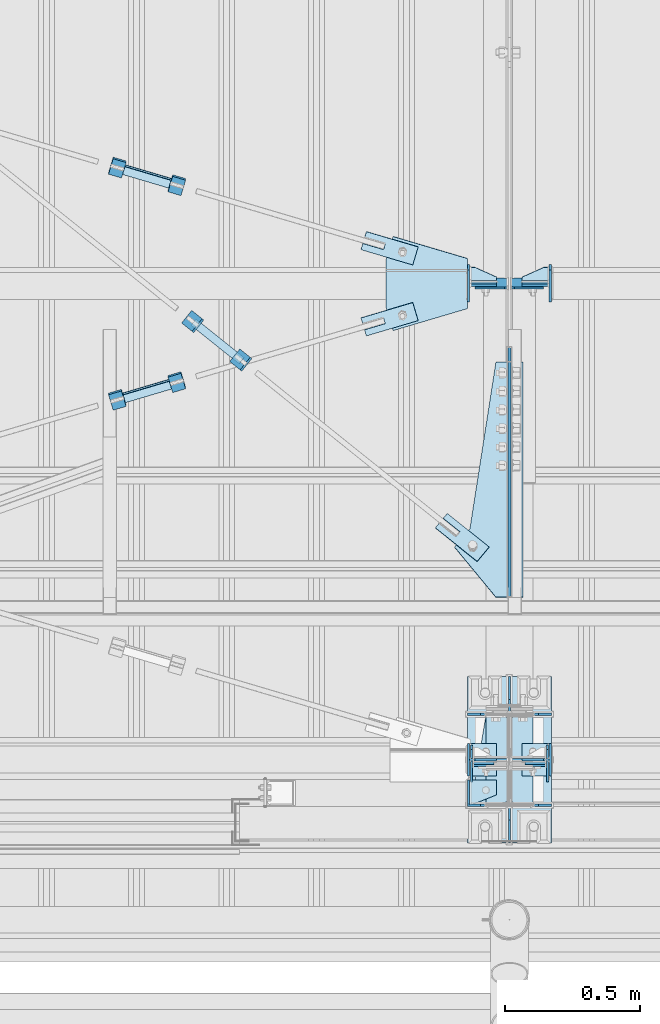
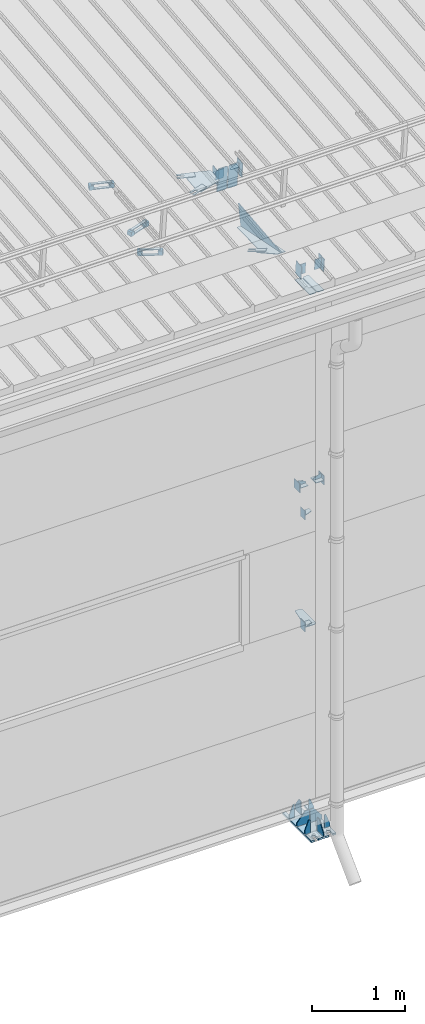
# One storey, part 112 of 709: 52 plates, 6 openings, 16 elements without a shape of their own.
"""IFC4 building model written with IfcOpenShell, lengths in millimetres."""

from ifc_helpers import new_model, si_unit, direction, frame, origin_with_axes, place, context, subcontext, project, spatial, line, arc, indexed_curve, outline, extrude, material, element, aggregate, save


model = new_model("IFC4")

# Units and contexts
model_context = context("Model", 3, precision=0.2, world=origin_with_axes(), true_north=direction((0.0, 1.0)))
body_context = subcontext(model_context, "Body", "Model", "MODEL_VIEW")
ifc_project = project(units=[si_unit("LENGTHUNIT", "METRE", prefix="MILLI"), si_unit("AREAUNIT", "SQUARE_METRE"), si_unit("VOLUMEUNIT", "CUBIC_METRE"), si_unit("MASSUNIT", "GRAM", prefix="KILO"), si_unit("TIMEUNIT", "SECOND"), si_unit("PLANEANGLEUNIT", "RADIAN"), si_unit("SOLIDANGLEUNIT", "STERADIAN"), si_unit("THERMODYNAMICTEMPERATUREUNIT", "DEGREE_CELSIUS"), si_unit("LUMINOUSINTENSITYUNIT", "LUMEN")], contexts=[model_context])

# Site, building, storey
site_placement = place(None, origin_with_axes())
site = spatial("IfcSite", under=ifc_project, at=site_placement, CompositionType="ELEMENT")
building_placement = place(site_placement, origin_with_axes())
building = spatial("IfcBuilding", under=site, at=building_placement, Name="Undefined", CompositionType="ELEMENT")
storey_placement = place(building_placement, origin_with_axes())
storey = spatial("IfcBuildingStorey", under=building, at=storey_placement, Name="Undefined", CompositionType="ELEMENT", Elevation=0.0)

# Assembly, plates, voiding features
assembly_1_placement = place(storey_placement, frame((10000.0, 173.0, -200.0), z_axis=(-1.0, 0.0, 0.0), x_axis=(0.0, 0.0, 1.0)))
assembly_1 = element("IfcElementAssembly", 1, at=assembly_1_placement, inside=storey)
ifc_material_1 = material(Name="C355-6", Category="STEEL")
plate_1_placement = place(assembly_1_placement, frame((2742.0, 163.0, 4.0), z_axis=(1.0, 0.0, 0.0), x_axis=(0.0, 0.0, 1.0)))
plate_1 = element("IfcPlate", 2, at=plate_1_placement, material=ifc_material_1, ObjectType="543", context=body_context, shape_type="SolidModel", body=[
    extrude(outline(indexed_curve([(0.0, 20.0), (20.0, 0.0), (83.0, 0.0), (123.0, 240.0), (123.0, 326.0), (20.0, 326.0), (0.0, 306.0)], segments=[line(1, 2, 3, 4, 5, 6, 7, 1)])), frame((0.0, 0.0, 4.0), z_axis=(0.0, 0.0, 1.0), x_axis=(1.0, 0.0, 0.0)), (0.0, 0.0, -1.0), 8.0),
])
plate_2_placement = place(assembly_1_placement, frame((7097.93718, 163.0, 87.0), z_axis=(-1.0, 0.0, 0.0), x_axis=(0.0, 0.0, -1.0)))
plate_2 = element("IfcPlate", 3, at=plate_2_placement, material=ifc_material_1, ObjectType="461", context=body_context, shape_type="SolidModel", body=[
    extrude(outline(indexed_curve([(0.0, 0.0), (68.0, 0.0), (83.0, 15.0), (83.0, 311.0), (68.0, 326.0), (0.0, 326.0)], segments=[line(1, 2, 3, 4, 5, 6, 1)])), frame((0.0, 0.0, 4.0), z_axis=(0.0, 0.0, 1.0), x_axis=(1.0, 0.0, 0.0)), (0.0, 0.0, -1.0), 8.0),
])
plate_3_placement = place(assembly_1_placement, frame((7097.93718, -163.0, -87.0), z_axis=(-1.0, 0.0, 0.0), x_axis=(0.0, 0.0, 1.0)))
plate_3 = element("IfcPlate", 4, at=plate_3_placement, material=ifc_material_1, ObjectType="461", context=body_context, shape_type="SolidModel", body=[
    extrude(outline(indexed_curve([(0.0, 0.0), (68.0, 0.0), (83.0, 15.0), (83.0, 311.0), (68.0, 326.0), (0.0, 326.0)], segments=[line(1, 2, 3, 4, 5, 6, 1)])), frame((0.0, 0.0, 4.0), z_axis=(0.0, 0.0, 1.0), x_axis=(1.0, 0.0, 0.0)), (0.0, 0.0, -1.0), 8.0),
])
plate_4_placement = place(assembly_1_placement, frame((25.0, -173.0, 0.0), z_axis=(0.0, 0.0, 1.0), x_axis=(0.0, -1.0, 0.0)))
plate_4 = element("IfcPlate", 5, at=plate_4_placement, material=ifc_material_1, ObjectType="418", context=body_context, shape_type="SolidModel", body=[
    extrude(outline(indexed_curve([(0.0, 0.0), (135.0, 0.0), (135.0, 50.0), (50.0, 175.0), (0.0, 175.0)], segments=[line(1, 2, 3, 4, 5, 1)])), frame((0.0, 0.0, 4.0), z_axis=(0.0, 0.0, 1.0), x_axis=(1.0, 0.0, 0.0)), (0.0, 0.0, -1.0), 8.0),
])
plate_5_placement = place(assembly_1_placement, frame((25.0, 173.0, 0.0), z_axis=(0.0, 0.0, -1.0), x_axis=(0.0, 1.0, 0.0)))
plate_5 = element("IfcPlate", 6, at=plate_5_placement, material=ifc_material_1, ObjectType="418", context=body_context, shape_type="SolidModel", body=[
    extrude(outline(indexed_curve([(0.0, 0.0), (135.0, 0.0), (135.0, 50.0), (50.0, 175.0), (0.0, 175.0)], segments=[line(1, 2, 3, 4, 5, 1)])), frame((0.0, 0.0, 4.0), z_axis=(0.0, 0.0, 1.0), x_axis=(1.0, 0.0, 0.0)), (0.0, 0.0, -1.0), 8.0),
])
plate_6_placement = place(assembly_1_placement, frame((25.0, 168.5, -87.0), z_axis=(0.0, -1.0, 0.0), x_axis=(0.0, 0.0, -1.0)))
plate_6 = element("IfcPlate", 7, at=plate_6_placement, material=ifc_material_1, ObjectType="419", context=body_context, shape_type="SolidModel", body=[
    extrude(outline(indexed_curve([(0.0, 0.0), (68.0, 0.0), (68.0, 50.0), (20.0, 175.0), (0.0, 175.0)], segments=[line(1, 2, 3, 4, 5, 1)])), frame((0.0, 0.0, 4.0), z_axis=(0.0, 0.0, 1.0), x_axis=(1.0, 0.0, 0.0)), (0.0, 0.0, -1.0), 8.0),
])
plate_7_placement = place(assembly_1_placement, frame((25.0, -168.5, 87.0), z_axis=(0.0, 1.0, 0.0), x_axis=(0.0, 0.0, 1.0)))
plate_7 = element("IfcPlate", 8, at=plate_7_placement, material=ifc_material_1, ObjectType="419", context=body_context, shape_type="SolidModel", body=[
    extrude(outline(indexed_curve([(0.0, 0.0), (68.0, 0.0), (68.0, 50.0), (20.0, 175.0), (0.0, 175.0)], segments=[line(1, 2, 3, 4, 5, 1)])), frame((0.0, 0.0, 4.0), z_axis=(0.0, 0.0, 1.0), x_axis=(1.0, 0.0, 0.0)), (0.0, 0.0, -1.0), 8.0),
])
plate_8_placement = place(assembly_1_placement, frame((25.0, -168.5, -87.0), z_axis=(0.0, -1.0, 0.0), x_axis=(0.0, 0.0, -1.0)))
plate_8 = element("IfcPlate", 9, at=plate_8_placement, material=ifc_material_1, ObjectType="419", context=body_context, shape_type="SolidModel", body=[
    extrude(outline(indexed_curve([(0.0, 0.0), (68.0, 0.0), (68.0, 50.0), (20.0, 175.0), (0.0, 175.0)], segments=[line(1, 2, 3, 4, 5, 1)])), frame((0.0, 0.0, 4.0), z_axis=(0.0, 0.0, 1.0), x_axis=(1.0, 0.0, 0.0)), (0.0, 0.0, -1.0), 8.0),
])
plate_9_placement = place(assembly_1_placement, frame((25.0, 168.5, 87.0), z_axis=(0.0, 1.0, 0.0), x_axis=(0.0, 0.0, 1.0)))
plate_9 = element("IfcPlate", 10, at=plate_9_placement, material=ifc_material_1, ObjectType="419", context=body_context, shape_type="SolidModel", body=[
    extrude(outline(indexed_curve([(0.0, 0.0), (68.0, 0.0), (68.0, 50.0), (20.0, 175.0), (0.0, 175.0)], segments=[line(1, 2, 3, 4, 5, 1)])), frame((0.0, 0.0, 4.0), z_axis=(0.0, 0.0, 1.0), x_axis=(1.0, 0.0, 0.0)), (0.0, 0.0, -1.0), 8.0),
])
plate_10_placement = place(assembly_1_placement, frame((25.0, 0.0, -3.0), z_axis=(0.0, -1.0, 0.0), x_axis=(0.0, 0.0, -1.0)))
plate_10 = element("IfcPlate", 11, at=plate_10_placement, material=ifc_material_1, ObjectType="417", context=body_context, shape_type="SolidModel", body=[
    extrude(outline(indexed_curve([(0.0, 0.0), (152.0, 0.0), (152.0, 50.0), (50.0, 175.0), (0.0, 175.0)], segments=[line(1, 2, 3, 4, 5, 1)])), frame((0.0, 0.0, 4.0), z_axis=(0.0, 0.0, 1.0), x_axis=(1.0, 0.0, 0.0)), (0.0, 0.0, -1.0), 8.0),
])
plate_11_placement = place(assembly_1_placement, frame((12.5, -308.0, 155.0), z_axis=(1.0, 0.0, 0.0), x_axis=(0.0, 0.0, -1.0)))
plate_11 = element("IfcPlate", 12, at=plate_11_placement, material=ifc_material_1, ObjectType="416", context=body_context, shape_type="SolidModel", body=[
    extrude(outline(indexed_curve([(0.0, 0.0), (310.0, 0.0), (310.0, 616.0), (0.0, 616.0)], segments=[line(1, 2, 3, 4, 1)])), frame((0.0, 0.0, 12.5), z_axis=(0.0, 0.0, 1.0), x_axis=(1.0, 0.0, 0.0)), (0.0, 0.0, -1.0), 25.0),
])
voiding_feature_1_placement = place(plate_11_placement, frame((40.0, 616.0, 0.0), z_axis=(0.0, 0.0, -1.0), x_axis=(1.0, 0.0, 0.0)))
element("IfcVoidingFeature", 13, at=voiding_feature_1_placement, cuts=plate_11, PredefinedType="HOLE", context=body_context, shape_type="SolidModel", body=[
    extrude(outline(indexed_curve([(0.0, 0.0), (50.0, 0.0), (50.0, 60.0), (42.67767, 77.67767), (25.0, 85.0), (25.0, 85.0), (7.32233, 77.67767), (0.0, 60.0)], segments=[line(1, 2, 3), arc(3, 4, 5), line(5, 6), arc(6, 7, 8), line(8, 1)])), frame((0.0, 0.0, 12.5), z_axis=(0.0, 0.0, 1.0), x_axis=(1.0, 0.0, 0.0)), (0.0, 0.0, -1.0), 25.0),
])
voiding_feature_2_placement = place(plate_11_placement, frame((40.0, 0.0, 0.0), z_axis=(0.0, 0.0, 1.0), x_axis=(1.0, 0.0, 0.0)))
element("IfcVoidingFeature", 14, at=voiding_feature_2_placement, cuts=plate_11, PredefinedType="HOLE", context=body_context, shape_type="SolidModel", body=[
    extrude(outline(indexed_curve([(0.0, 0.0), (50.0, 0.0), (50.0, 60.0), (42.67767, 77.67767), (25.0, 85.0), (25.0, 85.0), (7.32233, 77.67767), (0.0, 60.0)], segments=[line(1, 2, 3), arc(3, 4, 5), line(5, 6), arc(6, 7, 8), line(8, 1)])), frame((0.0, 0.0, 12.5), z_axis=(0.0, 0.0, 1.0), x_axis=(1.0, 0.0, 0.0)), (0.0, 0.0, -1.0), 25.0),
])
voiding_feature_3_placement = place(plate_11_placement, frame((270.0, 616.0, 0.0), z_axis=(0.0, 0.0, 1.0), x_axis=(-1.0, 0.0, 0.0)))
element("IfcVoidingFeature", 15, at=voiding_feature_3_placement, cuts=plate_11, PredefinedType="HOLE", context=body_context, shape_type="SolidModel", body=[
    extrude(outline(indexed_curve([(0.0, 0.0), (50.0, 0.0), (50.0, 60.0), (42.67767, 77.67767), (25.0, 85.0), (25.0, 85.0), (7.32233, 77.67767), (0.0, 60.0)], segments=[line(1, 2, 3), arc(3, 4, 5), line(5, 6), arc(6, 7, 8), line(8, 1)])), frame((0.0, 0.0, 12.5), z_axis=(0.0, 0.0, 1.0), x_axis=(1.0, 0.0, 0.0)), (0.0, 0.0, -1.0), 25.0),
])
voiding_feature_4_placement = place(plate_11_placement, frame((270.0, 0.0, 0.0), z_axis=(0.0, 0.0, -1.0), x_axis=(-1.0, 0.0, 0.0)))
element("IfcVoidingFeature", 16, at=voiding_feature_4_placement, cuts=plate_11, PredefinedType="HOLE", context=body_context, shape_type="SolidModel", body=[
    extrude(outline(indexed_curve([(0.0, 0.0), (50.0, 0.0), (50.0, 60.0), (42.67767, 77.67767), (25.0, 85.0), (25.0, 85.0), (7.32233, 77.67767), (0.0, 60.0)], segments=[line(1, 2, 3), arc(3, 4, 5), line(5, 6), arc(6, 7, 8), line(8, 1)])), frame((0.0, 0.0, 12.5), z_axis=(0.0, 0.0, 1.0), x_axis=(1.0, 0.0, 0.0)), (0.0, 0.0, -1.0), 25.0),
])
plate_12_placement = place(assembly_1_placement, frame((25.0, 0.0, 3.0), z_axis=(0.0, 1.0, 0.0), x_axis=(0.0, 0.0, 1.0)))
plate_12 = element("IfcPlate", 17, at=plate_12_placement, material=ifc_material_1, ObjectType="417", context=body_context, shape_type="SolidModel", body=[
    extrude(outline(indexed_curve([(0.0, 0.0), (152.0, 0.0), (152.0, 50.0), (50.0, 175.0), (0.0, 175.0)], segments=[line(1, 2, 3, 4, 5, 1)])), frame((0.0, 0.0, 4.0), z_axis=(0.0, 0.0, 1.0), x_axis=(1.0, 0.0, 0.0)), (0.0, 0.0, -1.0), 8.0),
])
aggregate(assembly_1, [plate_1, plate_2, plate_3, plate_4, plate_5, plate_6, plate_7, plate_8, plate_9, plate_10, plate_11, plate_12])

# Assembly, plates
assembly_2_placement = place(storey_placement, frame((10000.0, 346.0, 7089.70002), z_axis=(1.0, 0.0, 0.0), x_axis=(0.0, 0.9950371902, 0.099503719)))
assembly_2 = element("IfcElementAssembly", 18, at=assembly_2_placement, inside=storey)
plate_13_placement = place(assembly_2_placement, frame((412.62035, -176.8248, 50.0), z_axis=(0.2927142719, 0.9561999556, 0.0), x_axis=(0.9561999556, -0.2927142719, 0.0)))
plate_13 = element("IfcPlate", 19, at=plate_13_placement, material=ifc_material_1, ObjectType="489", context=body_context, shape_type="SolidModel", body=[
    extrude(outline(indexed_curve([(0.0, 0.0), (887.65935, 0.0), (887.65935, 100.0), (259.05365, 196.23068), (189.37305, 253.1922), (0.0, 100.0)], segments=[line(1, 2, 3, 4, 5, 6, 1)])), frame((0.0, 0.0, 4.0), z_axis=(0.0, 0.0, 1.0), x_axis=(1.0, 0.0, 0.0)), (0.0, 0.0, -1.0), 8.0),
])
plate_14_placement = place(assembly_2_placement, frame((1342.111, -173.0, 0.0), z_axis=(0.0, 0.0, 1.0), x_axis=(-1.0, 0.0, 0.0)))
plate_14 = element("IfcPlate", 20, at=plate_14_placement, material=ifc_material_1, ObjectType="449", context=body_context, shape_type="SolidModel", body=[
    extrude(outline(indexed_curve([(0.0, 0.0), (928.3198, 0.0), (79.53997, 259.83056)], segments=[line(1, 2, 3, 1)])), frame((0.0, 0.0, 6.0), z_axis=(0.0, 0.0, 1.0), x_axis=(1.0, 0.0, 0.0)), (0.0, 0.0, -1.0), 12.0),
])
plate_15_placement = place(assembly_2_placement, frame((1597.88359, 163.0, -127.0), z_axis=(1.0, 0.0, 0.0), x_axis=(0.0, 0.0, 1.0)))
plate_15 = element("IfcPlate", 21, at=plate_15_placement, material=ifc_material_1, ObjectType="585", context=body_context, shape_type="SolidModel", body=[
    extrude(outline(indexed_curve([(0.0, 0.0), (108.0, 0.0), (123.0, 15.0), (123.0, 311.0), (108.0, 326.0), (0.0, 326.0)], segments=[line(1, 2, 3, 4, 5, 6, 1)])), frame((0.0, 0.0, 4.0), z_axis=(0.0, 0.0, 1.0), x_axis=(1.0, 0.0, 0.0)), (0.0, 0.0, -1.0), 8.0),
])
plate_16_placement = place(assembly_2_placement, frame((1597.88359, 163.0, 127.0), z_axis=(-1.0, 0.0, 0.0), x_axis=(0.0, 0.0, -1.0)))
plate_16 = element("IfcPlate", 22, at=plate_16_placement, material=ifc_material_1, ObjectType="585", context=body_context, shape_type="SolidModel", body=[
    extrude(outline(indexed_curve([(0.0, 0.0), (108.0, 0.0), (123.0, 15.0), (123.0, 311.0), (108.0, 326.0), (0.0, 326.0)], segments=[line(1, 2, 3, 4, 5, 6, 1)])), frame((0.0, 0.0, 4.0), z_axis=(0.0, 0.0, 1.0), x_axis=(1.0, 0.0, 0.0)), (0.0, 0.0, -1.0), 8.0),
])
aggregate(assembly_2, [plate_13, plate_14, plate_15, plate_16])

# Assembly, plate
assembly_3_placement = place(storey_placement, frame((8916.07962, 1724.40956, 6772.92001), z_axis=(-0.625451877, -0.7802627439, 1e-10), x_axis=(0.7742288439, -0.6206151549, 0.124123031)))
assembly_3 = element("IfcElementAssembly", 23, at=assembly_3_placement, inside=storey)
plate_17_placement = place(assembly_3_placement, frame((1074.34134, 5.35577, 34.5878), z_axis=(1e-10, 0.9882227648, -0.1530221135), x_axis=(1.0, 0.0, 0.0)))
plate_17 = element("IfcPlate", 24, at=plate_17_placement, material=ifc_material_1, ObjectType="490", context=body_context, shape_type="SolidModel", body=[
    extrude(outline(indexed_curve([(0.0, 0.0), (200.0, 0.0), (200.0, 70.0), (0.0, 70.0), (0.0, 46.0), (80.0, 46.0), (80.0, 24.0), (0.0, 24.0)], segments=[line(1, 2, 3, 4, 5, 6, 7, 8, 1)])), frame((0.0, 0.0, 4.0), z_axis=(0.0, 0.0, 1.0), x_axis=(1.0, 0.0, 0.0)), (0.0, 0.0, -1.0), 8.0),
])
aggregate(assembly_3, [plate_17])

# Assembly, plates
assembly_4_placement = place(storey_placement, frame((8983.44692, 1631.95992, 6816.96217), z_axis=(-0.7742288439, 0.6206151548, -0.1241230313), x_axis=(0.625451877, 0.780262744, 0.0)))
assembly_4 = element("IfcElementAssembly", 25, at=assembly_4_placement, inside=storey)
ifc_material_2 = material(Name="Steel_Undefined", Category="STEEL")
plate_18_placement = place(assembly_4_placement, origin_with_axes())
plate_18 = element("IfcPlate", 26, at=plate_18_placement, material=ifc_material_2, ObjectType="482", context=body_context, shape_type="SolidModel", body=[
    extrude(outline(indexed_curve([(0.0, 0.0), (60.0, 0.0), (60.0, 60.0), (0.0, 60.0)], segments=[line(1, 2, 3, 4, 1)])), frame((0.0, 0.0, 25.0), z_axis=(0.0, 0.0, 1.0), x_axis=(1.0, 0.0, 0.0)), (0.0, 0.0, -1.0), 50.0),
])
plate_19_placement = place(assembly_4_placement, frame((15.0, 66.0, 230.0), z_axis=(0.0, 1.0, 0.0), x_axis=(1.0, 0.0, 0.0)))
plate_19 = element("IfcPlate", 27, at=plate_19_placement, material=ifc_material_2, ObjectType="484", context=body_context, shape_type="SolidModel", body=[
    extrude(outline(indexed_curve([(0.0, 0.0), (30.0, 0.0), (30.0, 230.0), (0.0, 230.0)], segments=[line(1, 2, 3, 4, 1)])), frame((0.0, 0.0, 6.0), z_axis=(0.0, 0.0, 1.0), x_axis=(1.0, 0.0, 0.0)), (0.0, 0.0, -1.0), 12.0),
])
plate_20_placement = place(assembly_4_placement, frame((15.0, -6.0, 230.0), z_axis=(0.0, 1.0, 0.0), x_axis=(1.0, 0.0, 0.0)))
plate_20 = element("IfcPlate", 28, at=plate_20_placement, material=ifc_material_2, ObjectType="484", context=body_context, shape_type="SolidModel", body=[
    extrude(outline(indexed_curve([(0.0, 0.0), (30.0, 0.0), (30.0, 230.0), (0.0, 230.0)], segments=[line(1, 2, 3, 4, 1)])), frame((0.0, 0.0, 6.0), z_axis=(0.0, 0.0, 1.0), x_axis=(1.0, 0.0, 0.0)), (0.0, 0.0, -1.0), 12.0),
])
plate_21_placement = place(assembly_4_placement, frame((0.0, 0.0, 230.0), z_axis=(0.0, 0.0, 1.0), x_axis=(1.0, 0.0, 0.0)))
plate_21 = element("IfcPlate", 29, at=plate_21_placement, material=ifc_material_2, ObjectType="483", context=body_context, shape_type="SolidModel", body=[
    extrude(outline(indexed_curve([(0.0, 0.0), (60.0, 0.0), (60.0, 60.0), (0.0, 60.0)], segments=[line(1, 2, 3, 4, 1)])), frame((0.0, 0.0, 25.0), z_axis=(0.0, 0.0, 1.0), x_axis=(1.0, 0.0, 0.0)), (0.0, 0.0, -1.0), 50.0),
])
aggregate(assembly_4, [plate_18, plate_19, plate_20, plate_21])

assembly_5_placement = place(storey_placement, frame((4000.0, 50.0, 2550.0), z_axis=(0.0, 0.0, -1.0), x_axis=(1.0, 0.0, 0.0)))
assembly_5 = element("IfcElementAssembly", 30, at=assembly_5_placement, inside=storey)
plate_22_placement = place(assembly_5_placement, frame((5849.0, 47.0, -60.0), z_axis=(-1.0, 0.0, 0.0), x_axis=(0.0, -1.0, 0.0)))
plate_22 = element("IfcPlate", 31, at=plate_22_placement, material=ifc_material_1, ObjectType="501", context=body_context, shape_type="SolidModel", body=[
    extrude(outline(indexed_curve([(0.0, 0.0), (94.0, 0.0), (94.0, 120.0), (0.0, 120.0)], segments=[line(1, 2, 3, 4, 1)])), frame((0.0, 0.0, 4.0), z_axis=(0.0, 0.0, 1.0), x_axis=(1.0, 0.0, 0.0)), (0.0, 0.0, -1.0), 8.0),
])
plate_23_placement = place(assembly_5_placement, frame((5853.0, 47.0, 0.0), z_axis=(0.0, 0.0, 1.0), x_axis=(0.0, -1.0, 0.0)))
plate_23 = element("IfcPlate", 32, at=plate_23_placement, material=ifc_material_1, ObjectType="502", context=body_context, shape_type="SolidModel", body=[
    extrude(outline(indexed_curve([(0.0, 0.0), (94.0, 0.0), (94.0, 100.0), (40.0, 100.0), (0.0, 0.0)], segments=[line(1, 2, 3, 4, 5, 1)])), frame((0.0, 0.0, 4.0), z_axis=(0.0, 0.0, 1.0), x_axis=(1.0, 0.0, 0.0)), (0.0, 0.0, -1.0), 8.0),
])
aggregate(assembly_5, [plate_22, plate_23])

assembly_6_placement = place(storey_placement, frame((4000.0, 50.0, 4020.0), z_axis=(0.0, 0.0, -1.0), x_axis=(1.0, 0.0, 0.0)))
assembly_6 = element("IfcElementAssembly", 33, at=assembly_6_placement, inside=storey)
plate_24_placement = place(assembly_6_placement, frame((5853.0, 47.0, 0.0), z_axis=(0.0, 0.0, 1.0), x_axis=(0.0, -1.0, 0.0)))
plate_24 = element("IfcPlate", 34, at=plate_24_placement, material=ifc_material_1, ObjectType="502", context=body_context, shape_type="SolidModel", body=[
    extrude(outline(indexed_curve([(0.0, 0.0), (94.0, 0.0), (94.0, 100.0), (40.0, 100.0), (0.0, 0.0)], segments=[line(1, 2, 3, 4, 5, 1)])), frame((0.0, 0.0, 4.0), z_axis=(0.0, 0.0, 1.0), x_axis=(1.0, 0.0, 0.0)), (0.0, 0.0, -1.0), 8.0),
])
plate_25_placement = place(assembly_6_placement, frame((5849.0, 47.0, -60.0), z_axis=(-1.0, 0.0, 0.0), x_axis=(0.0, -1.0, 0.0)))
plate_25 = element("IfcPlate", 35, at=plate_25_placement, material=ifc_material_1, ObjectType="501", context=body_context, shape_type="SolidModel", body=[
    extrude(outline(indexed_curve([(0.0, 0.0), (94.0, 0.0), (94.0, 120.0), (0.0, 120.0)], segments=[line(1, 2, 3, 4, 1)])), frame((0.0, 0.0, 4.0), z_axis=(0.0, 0.0, 1.0), x_axis=(1.0, 0.0, 0.0)), (0.0, 0.0, -1.0), 8.0),
])
aggregate(assembly_6, [plate_24, plate_25])

assembly_7_placement = place(storey_placement, frame((4000.0, 173.0, 4310.0), z_axis=(0.0, 0.0, -1.0), x_axis=(1.0, 0.0, 0.0)))
assembly_7 = element("IfcElementAssembly", 36, at=assembly_7_placement, inside=storey)
plate_26_placement = place(assembly_7_placement, frame((5953.0, 0.0, -60.0), z_axis=(0.0, -1.0, 0.0), x_axis=(0.0, 0.0, 1.0)))
plate_26 = element("IfcPlate", 37, at=plate_26_placement, material=ifc_material_1, ObjectType="508", context=body_context, shape_type="SolidModel", body=[
    extrude(outline(indexed_curve([(0.0, 80.0), (36.0, 0.0), (56.0, 0.0), (56.0, 90.0), (46.0, 100.0), (0.0, 100.0)], segments=[line(1, 2, 3, 4, 5, 6, 1)])), frame((0.0, 0.0, 4.0), z_axis=(0.0, 0.0, 1.0), x_axis=(1.0, 0.0, 0.0)), (0.0, 0.0, -1.0), 8.0),
])
plate_27_placement = place(assembly_7_placement, frame((5849.0, -60.0, 60.0), z_axis=(1.0, 0.0, 0.0), x_axis=(0.0, 0.0, -1.0)))
plate_27 = element("IfcPlate", 38, at=plate_27_placement, material=ifc_material_1, ObjectType="506", context=body_context, shape_type="SolidModel", body=[
    extrude(outline(indexed_curve([(0.0, 0.0), (120.0, 0.0), (120.0, 120.0), (0.0, 120.0)], segments=[line(1, 2, 3, 4, 1)])), frame((0.0, 0.0, 4.0), z_axis=(0.0, 0.0, 1.0), x_axis=(1.0, 0.0, 0.0)), (0.0, 0.0, -1.0), 8.0),
])
plate_28_placement = place(assembly_7_placement, frame((5953.0, -60.0, 0.0), z_axis=(0.0, 0.0, 1.0), x_axis=(0.0, 1.0, 0.0)))
plate_28 = element("IfcPlate", 39, at=plate_28_placement, material=ifc_material_1, ObjectType="507", context=body_context, shape_type="SolidModel", body=[
    extrude(outline(indexed_curve([(0.0, 0.0), (120.0, 0.0), (120.0, 100.0), (0.0, 100.0)], segments=[line(1, 2, 3, 4, 1)])), frame((0.0, 0.0, 4.0), z_axis=(0.0, 0.0, 1.0), x_axis=(1.0, 0.0, 0.0)), (0.0, 0.0, -1.0), 8.0),
])
aggregate(assembly_7, [plate_26, plate_27, plate_28])

assembly_8_placement = place(storey_placement, frame((10000.0, 173.0, 4310.0), z_axis=(0.0, 0.0, -1.0), x_axis=(1.0, 0.0, 0.0)))
assembly_8 = element("IfcElementAssembly", 40, at=assembly_8_placement, inside=storey)
plate_29_placement = place(assembly_8_placement, frame((47.0, 60.0, 0.0), z_axis=(0.0, 0.0, 1.0), x_axis=(0.0, -1.0, 0.0)))
plate_29 = element("IfcPlate", 41, at=plate_29_placement, material=ifc_material_1, ObjectType="507", context=body_context, shape_type="SolidModel", body=[
    extrude(outline(indexed_curve([(0.0, 0.0), (120.0, 0.0), (120.0, 100.0), (0.0, 100.0)], segments=[line(1, 2, 3, 4, 1)])), frame((0.0, 0.0, 4.0), z_axis=(0.0, 0.0, 1.0), x_axis=(1.0, 0.0, 0.0)), (0.0, 0.0, -1.0), 8.0),
])
plate_30_placement = place(assembly_8_placement, frame((151.0, 60.0, 60.0), z_axis=(-1.0, 0.0, 0.0), x_axis=(0.0, 0.0, -1.0)))
plate_30 = element("IfcPlate", 42, at=plate_30_placement, material=ifc_material_1, ObjectType="506", context=body_context, shape_type="SolidModel", body=[
    extrude(outline(indexed_curve([(0.0, 0.0), (120.0, 0.0), (120.0, 120.0), (0.0, 120.0)], segments=[line(1, 2, 3, 4, 1)])), frame((0.0, 0.0, 4.0), z_axis=(0.0, 0.0, 1.0), x_axis=(1.0, 0.0, 0.0)), (0.0, 0.0, -1.0), 8.0),
])
plate_31_placement = place(assembly_8_placement, frame((47.0, 0.0, -60.0), z_axis=(0.0, 1.0, 0.0), x_axis=(0.0, 0.0, 1.0)))
plate_31 = element("IfcPlate", 43, at=plate_31_placement, material=ifc_material_1, ObjectType="508", context=body_context, shape_type="SolidModel", body=[
    extrude(outline(indexed_curve([(0.0, 80.0), (36.0, 0.0), (56.0, 0.0), (56.0, 90.0), (46.0, 100.0), (0.0, 100.0)], segments=[line(1, 2, 3, 4, 5, 6, 1)])), frame((0.0, 0.0, 4.0), z_axis=(0.0, 0.0, 1.0), x_axis=(1.0, 0.0, 0.0)), (0.0, 0.0, -1.0), 8.0),
])
aggregate(assembly_8, [plate_29, plate_30, plate_31])

# Assembly, plate, voiding feature
assembly_9_placement = place(storey_placement, frame((8658.15773, 1538.51229, 7290.35524), z_axis=(0.2852311229, -0.9537021177, -0.0953702118), x_axis=(0.9584587662, 0.2838155751, 0.028381558)))
assembly_9 = element("IfcElementAssembly", 44, at=assembly_9_placement, inside=storey)
plate_32_placement = place(assembly_9_placement, frame((1036.9749, 0.0, 35.0), z_axis=(0.0, 1.0, 0.0), x_axis=(0.0, 0.0, -1.0)))
plate_32 = element("IfcPlate", 45, at=plate_32_placement, material=ifc_material_1, ObjectType="574", context=body_context, shape_type="SolidModel", body=[
    extrude(outline(indexed_curve([(0.0, 0.0), (70.0, 0.0), (70.0, 200.0), (0.0, 200.0)], segments=[line(1, 2, 3, 4, 1)])), frame((0.0, 0.0, 4.0), z_axis=(0.0, 0.0, 1.0), x_axis=(1.0, 0.0, 0.0)), (0.0, 0.0, -1.0), 8.0),
])
voiding_feature_5_placement = place(plate_32_placement, frame((24.0, 120.0, 0.0), z_axis=(0.0, 0.0, 1.0), x_axis=(1.0, 0.0, 0.0)))
element("IfcVoidingFeature", 46, at=voiding_feature_5_placement, cuts=plate_32, Name="PLATE", PredefinedType="HOLE", context=body_context, shape_type="SolidModel", body=[
    extrude(outline(indexed_curve([(0.0, 0.0), (22.0, 0.0), (22.0, 85.0), (0.0, 85.0)], segments=[line(1, 2, 3, 4, 1)])), frame((0.0, 0.0, 6.5), z_axis=(0.0, 0.0, 1.0), x_axis=(1.0, 0.0, 0.0)), (0.0, 0.0, -1.0), 13.0),
])
aggregate(assembly_9, [plate_32])

# Assembly, plates
assembly_10_placement = place(storey_placement, frame((8776.93742, 1539.5549, 7320.60913), z_axis=(-0.9584587662, -0.2838155751, -0.0283815575), x_axis=(-0.2852311229, 0.9537021176, 0.095370212)))
assembly_10 = element("IfcElementAssembly", 47, at=assembly_10_placement, inside=storey)
plate_33_placement = place(assembly_10_placement, frame((15.0, -6.0, 230.0), z_axis=(0.0, 1.0, 0.0), x_axis=(1.0, 0.0, 0.0)))
plate_33 = element("IfcPlate", 48, at=plate_33_placement, material=ifc_material_2, ObjectType="484", context=body_context, shape_type="SolidModel", body=[
    extrude(outline(indexed_curve([(0.0, 0.0), (30.0, 0.0), (30.0, 230.0), (0.0, 230.0)], segments=[line(1, 2, 3, 4, 1)])), frame((0.0, 0.0, 6.0), z_axis=(0.0, 0.0, 1.0), x_axis=(1.0, 0.0, 0.0)), (0.0, 0.0, -1.0), 12.0),
])
plate_34_placement = place(assembly_10_placement, frame((0.0, 0.0, 230.0), z_axis=(0.0, 0.0, 1.0), x_axis=(1.0, 0.0, 0.0)))
plate_34 = element("IfcPlate", 49, at=plate_34_placement, material=ifc_material_2, ObjectType="483", context=body_context, shape_type="SolidModel", body=[
    extrude(outline(indexed_curve([(0.0, 0.0), (60.0, 0.0), (60.0, 60.0), (0.0, 60.0)], segments=[line(1, 2, 3, 4, 1)])), frame((0.0, 0.0, 25.0), z_axis=(0.0, 0.0, 1.0), x_axis=(1.0, 0.0, 0.0)), (0.0, 0.0, -1.0), 50.0),
])
plate_35_placement = place(assembly_10_placement, frame((15.0, 66.0, 230.0), z_axis=(0.0, 1.0, 0.0), x_axis=(1.0, 0.0, 0.0)))
plate_35 = element("IfcPlate", 50, at=plate_35_placement, material=ifc_material_2, ObjectType="484", context=body_context, shape_type="SolidModel", body=[
    extrude(outline(indexed_curve([(0.0, 0.0), (30.0, 0.0), (30.0, 230.0), (0.0, 230.0)], segments=[line(1, 2, 3, 4, 1)])), frame((0.0, 0.0, 6.0), z_axis=(0.0, 0.0, 1.0), x_axis=(1.0, 0.0, 0.0)), (0.0, 0.0, -1.0), 12.0),
])
plate_36_placement = place(assembly_10_placement, origin_with_axes())
plate_36 = element("IfcPlate", 51, at=plate_36_placement, material=ifc_material_2, ObjectType="482", context=body_context, shape_type="SolidModel", body=[
    extrude(outline(indexed_curve([(0.0, 0.0), (60.0, 0.0), (60.0, 60.0), (0.0, 60.0)], segments=[line(1, 2, 3, 4, 1)])), frame((0.0, 0.0, 25.0), z_axis=(0.0, 0.0, 1.0), x_axis=(1.0, 0.0, 0.0)), (0.0, 0.0, -1.0), 50.0),
])
aggregate(assembly_10, [plate_33, plate_34, plate_35, plate_36])

# Assembly, plate, voiding feature
assembly_11_placement = place(storey_placement, frame((8658.15773, 2333.1959, 7369.82361), z_axis=(-0.2852311229, -0.9537021177, -0.0953702118), x_axis=(0.9584587662, -0.2838155751, -0.028381558)))
assembly_11 = element("IfcElementAssembly", 52, at=assembly_11_placement, inside=storey)
plate_37_placement = place(assembly_11_placement, frame((1036.9749, 0.0, 35.0), z_axis=(0.0, 1.0, 0.0), x_axis=(0.0, 0.0, -1.0)))
plate_37 = element("IfcPlate", 53, at=plate_37_placement, material=ifc_material_1, ObjectType="574", context=body_context, shape_type="SolidModel", body=[
    extrude(outline(indexed_curve([(0.0, 0.0), (70.0, 0.0), (70.0, 200.0), (0.0, 200.0)], segments=[line(1, 2, 3, 4, 1)])), frame((0.0, 0.0, 4.0), z_axis=(0.0, 0.0, 1.0), x_axis=(1.0, 0.0, 0.0)), (0.0, 0.0, -1.0), 8.0),
])
voiding_feature_6_placement = place(plate_37_placement, frame((24.0, 120.0, 0.0), z_axis=(0.0, 0.0, 1.0), x_axis=(1.0, 0.0, 0.0)))
element("IfcVoidingFeature", 54, at=voiding_feature_6_placement, cuts=plate_37, Name="PLATE", PredefinedType="HOLE", context=body_context, shape_type="SolidModel", body=[
    extrude(outline(indexed_curve([(0.0, 0.0), (22.0, 0.0), (22.0, 85.0), (0.0, 85.0)], segments=[line(1, 2, 3, 4, 1)])), frame((0.0, 0.0, 6.5), z_axis=(0.0, 0.0, 1.0), x_axis=(1.0, 0.0, 0.0)), (0.0, 0.0, -1.0), 13.0),
])
aggregate(assembly_11, [plate_37])

# Assembly, plates
assembly_12_placement = place(storey_placement, frame((8759.82355, 2268.96093, 7393.54974), z_axis=(-0.9584587662, 0.2838155751, 0.0283815575), x_axis=(0.2852311229, 0.9537021176, 0.095370212)))
assembly_12 = element("IfcElementAssembly", 55, at=assembly_12_placement, inside=storey)
plate_38_placement = place(assembly_12_placement, frame((15.0, -6.0, 230.0), z_axis=(0.0, 1.0, 0.0), x_axis=(1.0, 0.0, 0.0)))
plate_38 = element("IfcPlate", 56, at=plate_38_placement, material=ifc_material_2, ObjectType="484", context=body_context, shape_type="SolidModel", body=[
    extrude(outline(indexed_curve([(0.0, 0.0), (30.0, 0.0), (30.0, 230.0), (0.0, 230.0)], segments=[line(1, 2, 3, 4, 1)])), frame((0.0, 0.0, 6.0), z_axis=(0.0, 0.0, 1.0), x_axis=(1.0, 0.0, 0.0)), (0.0, 0.0, -1.0), 12.0),
])
plate_39_placement = place(assembly_12_placement, frame((15.0, 66.0, 230.0), z_axis=(0.0, 1.0, 0.0), x_axis=(1.0, 0.0, 0.0)))
plate_39 = element("IfcPlate", 57, at=plate_39_placement, material=ifc_material_2, ObjectType="484", context=body_context, shape_type="SolidModel", body=[
    extrude(outline(indexed_curve([(0.0, 0.0), (30.0, 0.0), (30.0, 230.0), (0.0, 230.0)], segments=[line(1, 2, 3, 4, 1)])), frame((0.0, 0.0, 6.0), z_axis=(0.0, 0.0, 1.0), x_axis=(1.0, 0.0, 0.0)), (0.0, 0.0, -1.0), 12.0),
])
plate_40_placement = place(assembly_12_placement, frame((0.0, 0.0, 230.0), z_axis=(0.0, 0.0, 1.0), x_axis=(1.0, 0.0, 0.0)))
plate_40 = element("IfcPlate", 58, at=plate_40_placement, material=ifc_material_2, ObjectType="483", context=body_context, shape_type="SolidModel", body=[
    extrude(outline(indexed_curve([(0.0, 0.0), (60.0, 0.0), (60.0, 60.0), (0.0, 60.0)], segments=[line(1, 2, 3, 4, 1)])), frame((0.0, 0.0, 25.0), z_axis=(0.0, 0.0, 1.0), x_axis=(1.0, 0.0, 0.0)), (0.0, 0.0, -1.0), 50.0),
])
plate_41_placement = place(assembly_12_placement, origin_with_axes())
plate_41 = element("IfcPlate", 59, at=plate_41_placement, material=ifc_material_2, ObjectType="482", context=body_context, shape_type="SolidModel", body=[
    extrude(outline(indexed_curve([(0.0, 0.0), (60.0, 0.0), (60.0, 60.0), (0.0, 60.0)], segments=[line(1, 2, 3, 4, 1)])), frame((0.0, 0.0, 25.0), z_axis=(0.0, 0.0, 1.0), x_axis=(1.0, 0.0, 0.0)), (0.0, 0.0, -1.0), 50.0),
])
aggregate(assembly_12, [plate_38, plate_39, plate_40, plate_41])

assembly_13_placement = place(storey_placement, frame((4000.0, 158.95533, 7154.40952), z_axis=(0.0, 0.9950371902, 0.099503719), x_axis=(1.0, 0.0, 0.0)))
assembly_13 = element("IfcElementAssembly", 60, at=assembly_13_placement, inside=storey)
plate_42_placement = place(assembly_13_placement, frame((5943.0, 72.0, 0.0), z_axis=(0.0, 0.0, 1.0), x_axis=(-1.0, 0.0, 0.0)))
plate_42 = element("IfcPlate", 61, at=plate_42_placement, material=ifc_material_1, ObjectType="597", context=body_context, shape_type="SolidModel", body=[
    extrude(outline(indexed_curve([(0.0, 0.0), (80.0, 0.0), (80.0, 144.0), (0.0, 144.0)], segments=[line(1, 2, 3, 4, 1)])), frame((0.0, 0.0, 4.0), z_axis=(0.0, 0.0, 1.0), x_axis=(1.0, 0.0, 0.0)), (0.0, 0.0, -1.0), 8.0),
])
plate_43_placement = place(assembly_13_placement, frame((5859.0, -87.0, 60.0), z_axis=(1.0, 0.0, 0.0), x_axis=(0.0, 0.0, -1.0)))
plate_43 = element("IfcPlate", 62, at=plate_43_placement, material=ifc_material_1, ObjectType="596", context=body_context, shape_type="SolidModel", body=[
    extrude(outline(indexed_curve([(0.0, 0.0), (120.0, 0.0), (120.0, 174.0), (0.0, 174.0)], segments=[line(1, 2, 3, 4, 1)])), frame((0.0, 0.0, 4.0), z_axis=(0.0, 0.0, 1.0), x_axis=(1.0, 0.0, 0.0)), (0.0, 0.0, -1.0), 8.0),
])
aggregate(assembly_13, [plate_42, plate_43])

assembly_14_placement = place(storey_placement, frame((4000.0, 1936.65012, 7322.12913), z_axis=(0.0, 0.9950371902, 0.099503719), x_axis=(1.0, 0.0, 0.0)))
assembly_14 = element("IfcElementAssembly", 63, at=assembly_14_placement, inside=storey)
plate_44_placement = place(assembly_14_placement, frame((5953.0, 0.0, 60.0), z_axis=(0.0, -1.0, 0.0), x_axis=(-1.0, 0.0, 0.0)))
plate_44 = element("IfcPlate", 64, at=plate_44_placement, material=ifc_material_1, ObjectType="588", context=body_context, shape_type="SolidModel", body=[
    extrude(outline(indexed_curve([(0.0, 36.0), (80.0, 0.0), (100.0, 0.0), (100.0, 56.0), (0.0, 56.0)], segments=[line(1, 2, 3, 4, 5, 1)])), frame((0.0, 0.0, 4.0), z_axis=(0.0, 0.0, 1.0), x_axis=(1.0, 0.0, 0.0)), (0.0, 0.0, -1.0), 8.0),
])
plate_45_placement = place(assembly_14_placement, frame((5953.0, 65.0, 0.0), z_axis=(0.0, 0.0, 1.0), x_axis=(-1.0, 0.0, 0.0)))
plate_45 = element("IfcPlate", 65, at=plate_45_placement, material=ifc_material_1, ObjectType="587", context=body_context, shape_type="SolidModel", body=[
    extrude(outline(indexed_curve([(0.0, 0.0), (100.0, 0.0), (100.0, 130.0), (0.0, 130.0)], segments=[line(1, 2, 3, 4, 1)])), frame((0.0, 0.0, 4.0), z_axis=(0.0, 0.0, 1.0), x_axis=(1.0, 0.0, 0.0)), (0.0, 0.0, -1.0), 8.0),
])
plate_46_placement = place(assembly_14_placement, frame((5849.0, -98.0, 60.0), z_axis=(1.0, 0.0, 0.0), x_axis=(0.0, 0.0, -1.0)))
plate_46 = element("IfcPlate", 66, at=plate_46_placement, material=ifc_material_1, ObjectType="586", context=body_context, shape_type="SolidModel", body=[
    extrude(outline(indexed_curve([(0.0, 0.0), (120.0, 0.0), (120.0, 196.0), (0.0, 196.0)], segments=[line(1, 2, 3, 4, 1)])), frame((0.0, 0.0, 4.0), z_axis=(0.0, 0.0, 1.0), x_axis=(1.0, 0.0, 0.0)), (0.0, 0.0, -1.0), 8.0),
])
plate_47_placement = place(assembly_14_placement, frame((5845.00055, 0.0, -93.07721), z_axis=(0.0, -1.0, 0.0), x_axis=(0.0, 0.0, 1.0)))
plate_47 = element("IfcPlate", 67, at=plate_47_placement, material=ifc_material_1, ObjectType="576", context=body_context, shape_type="SolidModel", body=[
    extrude(outline(indexed_curve([(0.0, 0.0), (186.15442, 0.0), (268.27702, 275.95562), (182.01573, 301.62642), (4.13868, 301.62642), (-82.1226, 275.95562)], segments=[line(1, 2, 3, 4, 5, 6, 1)])), frame((0.0, 0.0, 4.0), z_axis=(0.0, 0.0, 1.0), x_axis=(1.0, 0.0, 0.0)), (0.0, 0.0, -1.0), 8.0),
])
aggregate(assembly_14, [plate_44, plate_45, plate_46, plate_47])

assembly_15_placement = place(storey_placement, frame((10000.0, 158.95533, 7154.40952), z_axis=(0.0, 0.9950371902, 0.099503719), x_axis=(1.0, 0.0, 0.0)))
assembly_15 = element("IfcElementAssembly", 68, at=assembly_15_placement, inside=storey)
plate_48_placement = place(assembly_15_placement, frame((57.0, -72.0, 0.0), z_axis=(0.0, 0.0, 1.0), x_axis=(1.0, 0.0, 0.0)))
plate_48 = element("IfcPlate", 69, at=plate_48_placement, material=ifc_material_1, ObjectType="597", context=body_context, shape_type="SolidModel", body=[
    extrude(outline(indexed_curve([(0.0, 0.0), (80.0, 0.0), (80.0, 144.0), (0.0, 144.0)], segments=[line(1, 2, 3, 4, 1)])), frame((0.0, 0.0, 4.0), z_axis=(0.0, 0.0, 1.0), x_axis=(1.0, 0.0, 0.0)), (0.0, 0.0, -1.0), 8.0),
])
plate_49_placement = place(assembly_15_placement, frame((141.0, -87.0, -60.0), z_axis=(-1.0, 0.0, 0.0), x_axis=(0.0, 0.0, 1.0)))
plate_49 = element("IfcPlate", 70, at=plate_49_placement, material=ifc_material_1, ObjectType="596", context=body_context, shape_type="SolidModel", body=[
    extrude(outline(indexed_curve([(0.0, 0.0), (120.0, 0.0), (120.0, 174.0), (0.0, 174.0)], segments=[line(1, 2, 3, 4, 1)])), frame((0.0, 0.0, 4.0), z_axis=(0.0, 0.0, 1.0), x_axis=(1.0, 0.0, 0.0)), (0.0, 0.0, -1.0), 8.0),
])
aggregate(assembly_15, [plate_48, plate_49])

assembly_16_placement = place(storey_placement, frame((10000.0, 1936.65012, 7322.12913), z_axis=(0.0, 0.9950371902, 0.099503719), x_axis=(1.0, 0.0, 0.0)))
assembly_16 = element("IfcElementAssembly", 71, at=assembly_16_placement, inside=storey)
plate_50_placement = place(assembly_16_placement, frame((47.0, -65.0, 0.0), z_axis=(0.0, 0.0, 1.0), x_axis=(1.0, 0.0, 0.0)))
plate_50 = element("IfcPlate", 72, at=plate_50_placement, material=ifc_material_1, ObjectType="587", context=body_context, shape_type="SolidModel", body=[
    extrude(outline(indexed_curve([(0.0, 0.0), (100.0, 0.0), (100.0, 130.0), (0.0, 130.0)], segments=[line(1, 2, 3, 4, 1)])), frame((0.0, 0.0, 4.0), z_axis=(0.0, 0.0, 1.0), x_axis=(1.0, 0.0, 0.0)), (0.0, 0.0, -1.0), 8.0),
])
plate_51_placement = place(assembly_16_placement, frame((47.0, 0.0, 60.0), z_axis=(0.0, 1.0, 0.0), x_axis=(1.0, 0.0, 0.0)))
plate_51 = element("IfcPlate", 73, at=plate_51_placement, material=ifc_material_1, ObjectType="588", context=body_context, shape_type="SolidModel", body=[
    extrude(outline(indexed_curve([(0.0, 36.0), (80.0, 0.0), (100.0, 0.0), (100.0, 56.0), (0.0, 56.0)], segments=[line(1, 2, 3, 4, 5, 1)])), frame((0.0, 0.0, 4.0), z_axis=(0.0, 0.0, 1.0), x_axis=(1.0, 0.0, 0.0)), (0.0, 0.0, -1.0), 8.0),
])
plate_52_placement = place(assembly_16_placement, frame((151.0, -98.0, -60.0), z_axis=(-1.0, 0.0, 0.0), x_axis=(0.0, 0.0, 1.0)))
plate_52 = element("IfcPlate", 74, at=plate_52_placement, material=ifc_material_1, ObjectType="586", context=body_context, shape_type="SolidModel", body=[
    extrude(outline(indexed_curve([(0.0, 0.0), (120.0, 0.0), (120.0, 196.0), (0.0, 196.0)], segments=[line(1, 2, 3, 4, 1)])), frame((0.0, 0.0, 4.0), z_axis=(0.0, 0.0, 1.0), x_axis=(1.0, 0.0, 0.0)), (0.0, 0.0, -1.0), 8.0),
])
aggregate(assembly_16, [plate_50, plate_51, plate_52])

save(model, "model.ifc")
